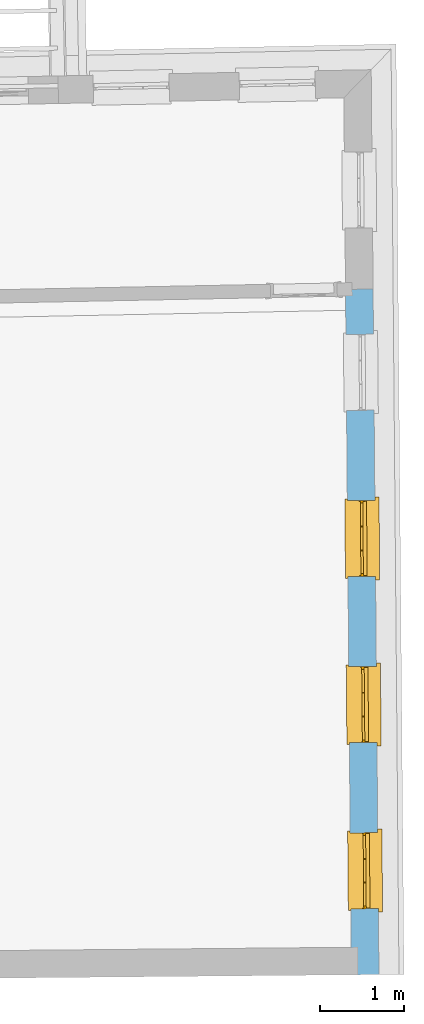
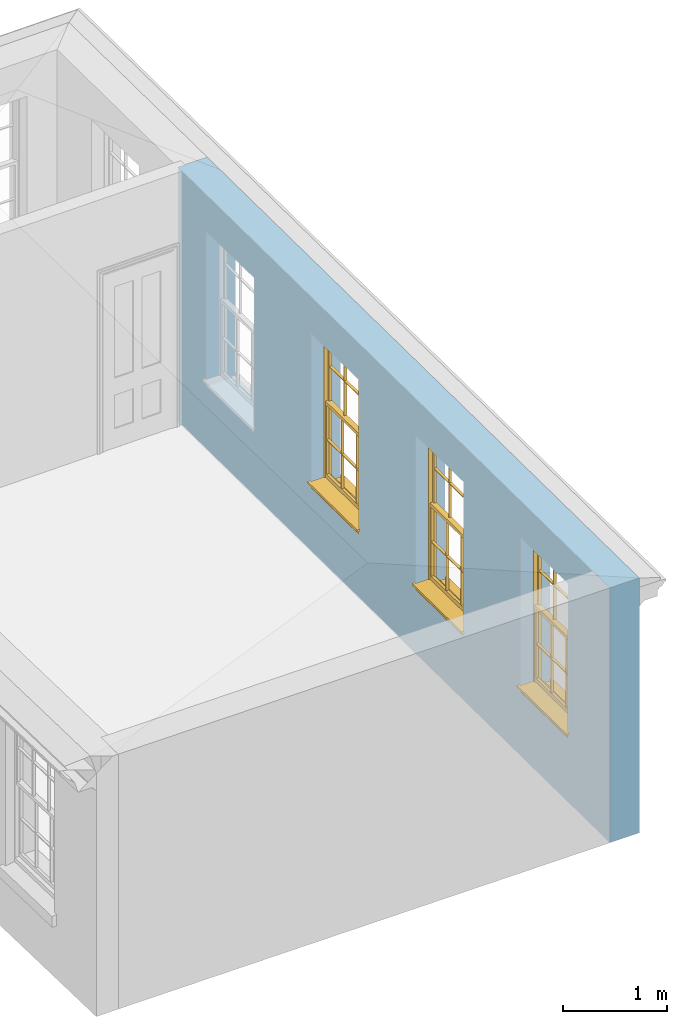
# One storey, part 4 of 11: 3 windows, 4 openings, plus 1 element that does not belong to this part.
"""IFC2X3 building model written with IfcOpenShell, lengths in metres."""

from ifc_helpers import new_model, si_unit, frame, origin, place, context, subcontext, project, spatial, polyline, outline, extrude, faceted_brep, material, layer, layer_set, layer_usage, element, fill, save


model = new_model("IFC2X3")

# Units and contexts
model_context = context("Model", 3, world=origin())
body_context = subcontext(model_context, "Body", "Model", "MODEL_VIEW")
ifc_project = project(units=[si_unit("PLANEANGLEUNIT", "RADIAN"), si_unit("MASSUNIT", "GRAM", prefix="KILO"), si_unit("FORCEUNIT", "NEWTON", prefix="KILO"), si_unit("LENGTHUNIT", "METRE")], contexts=[model_context])

# Site, building, storey
site_placement = place(None, origin())
site = spatial("IfcSite", under=ifc_project, at=site_placement, CompositionType="ELEMENT")
building_placement = place(None, origin())
building = spatial("IfcBuilding", under=site, at=building_placement, Name="Building plot-11", CompositionType="ELEMENT")
storey_placement = place(None, frame((0.0, 0.0, 5.3)))
storey = spatial("IfcBuildingStorey", under=building, at=storey_placement, Name="Floor 1", CompositionType="ELEMENT", Elevation=5.3)

# Wall, openings, windows
ifc_material = material(Name="Masonry")
ifc_layer = layer(ifc_material, 0.33, ventilated=False)
ifc_layer_set = layer_set([ifc_layer], Name="My Wall")
ifc_layer_usage = layer_usage(ifc_layer_set, "AXIS2", "NEGATIVE", 0.08)
wall_placement = place(storey_placement, origin())
wall = element("IfcWallStandardCase", 1, at=wall_placement, inside=storey, material=ifc_layer_usage, Name="exterior", context=body_context, shape_type="SweptSolid", body=[
    extrude(outline(polyline([(65.5837615155297, 12.2179906948306), (65.913749407515, 12.220817555827), (65.8434428524129, 20.4279108442136), (65.5134549604276, 20.4250839832172), (65.5837615155297, 12.2179906948306)])), origin(), (0.0, 0.0, 1.0), 3.0),
])
opening_1_placement = place(storey_placement, frame((0.0, 0.0, 0.75)))
opening_1 = element("IfcOpeningElement", 2, at=opening_1_placement, cuts=wall, Name="Opening", ObjectType="Opening", context=body_context, shape_type="SweptSolid", body=[
    extrude(outline(polyline([(65.9069848636133, 13.0104628851131), (65.8991895802596, 13.9204294963454), (65.5692016882743, 13.9176026353489), (65.576996971628, 13.0076360241167), (65.9069848636133, 13.0104628851131)])), origin(), (0.0, 0.0, 1.0), 1.82),
])
opening_2_placement = place(storey_placement, frame((0.0, 0.0, 0.75)))
opening_2 = element("IfcOpeningElement", 3, at=opening_2_placement, cuts=wall, Name="Opening", ObjectType="Opening", context=body_context, shape_type="SweptSolid", body=[
    extrude(outline(polyline([(65.889943615178, 14.9997385003944), (65.8821483318243, 15.9097051116266), (65.552160439839, 15.9068782506302), (65.5599557231927, 14.996911639398), (65.889943615178, 14.9997385003944)])), origin(), (0.0, 0.0, 1.0), 1.82),
])
opening_3_placement = place(storey_placement, frame((0.0, 0.0, 0.75)))
opening_3 = element("IfcOpeningElement", 4, at=opening_3_placement, cuts=wall, Name="Opening", ObjectType="Opening", context=body_context, shape_type="SweptSolid", body=[
    extrude(outline(polyline([(65.8729023667427, 16.9890141156756), (65.865107083389, 17.8989807269079), (65.5351191914037, 17.8961538659114), (65.5429144747574, 16.9861872546792), (65.8729023667427, 16.9890141156756)])), origin(), (0.0, 0.0, 1.0), 1.82),
])
opening_4_placement = place(storey_placement, frame((0.0, 0.0, 0.75)))
element("IfcOpeningElement", 5, at=opening_4_placement, cuts=wall, Name="Opening", ObjectType="Opening", context=body_context, shape_type="SweptSolid", body=[
    extrude(outline(polyline([(65.8558611183074, 18.9782897309569), (65.8480658349537, 19.8882563421891), (65.5180779429683, 19.8854294811927), (65.5258732263221, 18.9754628699605), (65.8558611183074, 18.9782897309569)])), origin(), (0.0, 0.0, 1.0), 1.82),
])
window_1_placement = place(storey_placement, frame((65.6569940363517, 13.0083213237522, 0.75), z_axis=(0.0, 0.0, 1.0), x_axis=(-0.00779528335375801, 0.909966611232212, 0.0)))
window_1 = element("IfcWindow", 6, at=window_1_placement, inside=storey, Name="bedroom outside window", OverallHeight=1.82, OverallWidth=0.91, context=body_context, shape_type="Brep", held_by="IfcProductRepresentation", body=[
    faceted_brep([(0.033125, -0.105, 0.975209), (0.01, -0.105, 0.975209), (0.033125, -0.105, 1.376042), (0.876875, -0.105, 0.975209), (0.876875, -0.105, 1.376042), (0.9, -0.105, 0.975209), (0.876875, -0.105, 1.386042), (0.876875, -0.105, 1.786875), (0.9, -0.105, 1.81), (0.033125, -0.105, 1.786875), (0.033125, -0.105, 1.386042), (0.01, -0.105, 1.81), (0.876875, -0.135, 1.376042), (0.876875, -0.135, 0.975209), (0.9, -0.135, 0.937083), (0.033125, -0.135, 1.786875), (0.01, -0.135, 1.81), (0.033125, -0.135, 1.386042), (0.01, -0.135, 0.937083), (0.033125, -0.135, 0.975209), (0.033125, -0.135, 1.376042), (0.876875, -0.135, 1.786875), (0.876875, -0.135, 1.386042), (0.9, -0.135, 1.81), (0.033125, -0.105, 0.937083), (0.01, -0.105, 0.937083), (0.033125, -0.105, 0.53625), (0.876875, -0.105, 0.937083), (0.876875, -0.105, 0.53625), (0.9, -0.105, 0.937083), (0.876875, -0.105, 0.52625), (0.876875, -0.105, 0.125417), (0.9, -0.105, 0.077167), (0.033125, -0.105, 0.125417), (0.033125, -0.105, 0.52625), (0.01, -0.105, 0.077167), (-0.0425, -0.25, 0.01), (-0.0425, -0.3, 0.001667), (0.0, -0.25, 0.01), (0.9525, -0.25, 0.01), (0.91, -0.25, 0.01), (0.9525, -0.3, 0.001667), (-0.02, 0.08, 0.077167), (0.0, 0.08, 0.077167), (-0.02, 0.11, 0.077167), (0.0, -0.06, 0.077167), (0.01, -0.06, 0.077167), (0.91, -0.06, 0.077167), (0.91, 0.08, 0.077167), (0.9, -0.06, 0.077167), (0.93, 0.08, 0.077167), (0.93, 0.11, 0.077167), (0.01, -0.075, 0.975209), (0.9, -0.075, 0.975209), (0.876875, -0.075, 0.125417), (0.876875, -0.075, 0.52625), (0.9, -0.075, 0.077167), (0.876875, -0.075, 0.53625), (0.876875, -0.075, 0.937083), (0.033125, -0.075, 0.125417), (0.01, -0.075, 0.077167), (0.033125, -0.075, 0.52625), (0.033125, -0.075, 0.937083), (0.033125, -0.075, 0.53625), (-0.02, 0.08, 0.052167), (-0.02, 0.11, 0.052167), (0.93, 0.11, 0.052167), (0.93, 0.08, 0.052167), (0.91, 0.08, 0.052167), (0.0, 0.08, 0.052167), (0.91, -0.15, 0.026667), (0.0, -0.15, 0.026667), (-0.0425, -0.3, -0.123333), (0.9525, -0.3, -0.123333), (-0.0425, -0.25, -0.123333), (0.9525, -0.25, -0.123333), (0.01, -0.06, 1.81), (0.9, -0.06, 1.81), (0.0, -0.06, 1.82), (0.91, -0.06, 1.82), (0.01, -0.15, 0.077167), (0.9, -0.15, 0.077167), (0.592292, -0.105, 0.125417), (0.592292, -0.075, 0.125417), (0.317708, -0.075, 0.125417), (0.317708, -0.105, 0.125417), (0.592292, -0.105, 0.53625), (0.317708, -0.105, 0.53625), (0.317708, -0.105, 0.52625), (0.592292, -0.105, 0.52625), (0.592292, -0.075, 0.53625), (0.317708, -0.075, 0.53625), (0.592292, -0.135, 1.386042), (0.592292, -0.105, 1.386042), (0.317708, -0.105, 1.386042), (0.317708, -0.135, 1.386042), (0.317708, -0.135, 1.376042), (0.592292, -0.135, 1.376042), (0.317708, -0.105, 1.376042), (0.592292, -0.105, 1.376042), (0.602292, -0.135, 1.376042), (0.592292, -0.135, 0.975209), (0.602292, -0.135, 0.975209), (0.602292, -0.105, 0.975209), (0.592292, -0.105, 0.975209), (0.602292, -0.105, 1.376042), (0.602292, -0.075, 0.53625), (0.602292, -0.105, 0.53625), (0.317708, -0.075, 0.52625), (0.307708, -0.075, 0.125417), (0.307708, -0.075, 0.52625), (0.602292, -0.075, 0.52625), (0.602292, -0.075, 0.125417), (0.592292, -0.075, 0.52625), (0.307708, -0.075, 0.53625), (0.317708, -0.075, 0.937083), (0.307708, -0.075, 0.937083), (0.602292, -0.075, 0.937083), (0.592292, -0.075, 0.937083), (0.307708, -0.105, 0.52625), (0.307708, -0.105, 0.125417), (0.307708, -0.105, 0.53625), (0.307708, -0.105, 0.937083), (0.592292, -0.105, 0.937083), (0.317708, -0.105, 0.937083), (0.602292, -0.105, 0.937083), (0.602292, -0.105, 0.52625), (0.602292, -0.105, 0.125417), (0.307708, -0.135, 1.386042), (0.307708, -0.135, 1.376042), (0.307708, -0.135, 0.975209), (0.317708, -0.135, 0.975209), (0.317708, -0.135, 1.786875), (0.307708, -0.135, 1.786875), (0.602292, -0.135, 1.786875), (0.592292, -0.135, 1.786875), (0.602292, -0.135, 1.386042), (0.602292, -0.105, 1.386042), (0.307708, -0.105, 1.386042), (0.307708, -0.105, 1.786875), (0.317708, -0.105, 1.786875), (0.592292, -0.105, 1.786875), (0.602292, -0.105, 1.786875), (0.307708, -0.105, 1.376042), (0.317708, -0.105, 0.975209), (0.307708, -0.105, 0.975209), (0.91, -0.15, 1.82), (0.9, -0.15, 1.81), (0.01, -0.15, 1.81), (0.0, -0.15, 1.82), (0.91, -0.25, 0.0), (0.0, -0.25, 0.0), (0.91, 0.08, 0.0), (0.0, 0.08, 0.0)], [[[0, 1, 2]], [[3, 4, 5]], [[6, 7, 8]], [[9, 10, 11]], [[12, 13, 14]], [[15, 16, 17]], [[18, 19, 20]], [[21, 22, 23]], [[24, 25, 26]], [[27, 28, 29]], [[30, 31, 32]], [[33, 34, 35]], [[14, 27, 29]], [[25, 24, 18]], [[36, 37, 38]], [[39, 40, 41]], [[42, 43, 44]], [[45, 46, 43]], [[47, 48, 49]], [[50, 51, 48]], [[1, 0, 52]], [[5, 53, 3]], [[54, 55, 56]], [[57, 58, 53]], [[59, 60, 61]], [[62, 63, 52]], [[48, 43, 46, 49]], [[51, 44, 43, 48]], [[64, 42, 44, 65]], [[65, 44, 51, 66]], [[66, 51, 50, 67]], [[65, 66, 68, 69]], [[60, 56, 49, 46]], [[70, 71, 38, 40]], [[37, 41, 40, 38]], [[37, 72, 73, 41]], [[74, 75, 73, 72]], [[8, 11, 76, 77]], [[76, 78, 79, 77]], [[32, 35, 80, 81]], [[81, 80, 71, 70]], [[82, 83, 84, 85]], [[86, 87, 88, 89]], [[86, 90, 91, 87]], [[92, 93, 94, 95]], [[92, 95, 96, 97]], [[96, 98, 99, 97]], [[100, 97, 101, 102]], [[103, 104, 99, 105]], [[97, 99, 104, 101]], [[102, 103, 105, 100]], [[28, 57, 106, 107]], [[108, 84, 109, 110]], [[111, 112, 83, 113]], [[114, 110, 61, 63]], [[90, 113, 108, 91]], [[115, 91, 114, 116]], [[117, 106, 90, 118]], [[111, 106, 57, 55]], [[119, 110, 109, 120]], [[34, 61, 110, 119]], [[89, 113, 83, 82]], [[88, 108, 113, 89]], [[85, 84, 108, 88]], [[121, 114, 63, 26]], [[122, 116, 114, 121]], [[123, 118, 90, 86]], [[87, 91, 115, 124]], [[107, 106, 117, 125]], [[126, 111, 55, 30]], [[127, 112, 111, 126]], [[126, 30, 28, 107]], [[88, 119, 120, 85]], [[126, 89, 82, 127]], [[125, 123, 86, 107]], [[121, 26, 34, 119]], [[124, 122, 121, 87]], [[128, 17, 20, 129]], [[96, 129, 130, 131]], [[132, 133, 128, 95]], [[134, 135, 92, 136]], [[100, 12, 22, 136]], [[137, 6, 4, 105]], [[94, 138, 139, 140]], [[137, 93, 141, 142]], [[99, 98, 94, 93]], [[143, 2, 10, 138]], [[144, 145, 143, 98]], [[129, 143, 145, 130]], [[20, 2, 143, 129]], [[131, 144, 98, 96]], [[128, 138, 10, 17]], [[133, 139, 138, 128]], [[135, 141, 93, 92]], [[95, 94, 140, 132]], [[22, 6, 137, 136]], [[136, 137, 142, 134]], [[100, 105, 4, 12]], [[107, 86, 89, 126]], [[106, 111, 113, 90]], [[91, 108, 110, 114]], [[87, 121, 119, 88]], [[97, 100, 136, 92]], [[129, 96, 95, 128]], [[98, 143, 138, 94]], [[105, 99, 93, 137]], [[131, 101, 104, 144]], [[124, 115, 118, 123]], [[132, 140, 141, 135]], [[120, 109, 59, 33]], [[15, 9, 139, 133]], [[134, 142, 7, 21]], [[31, 54, 112, 127]], [[36, 74, 72, 37]], [[39, 41, 73, 75]], [[18, 14, 101, 131]], [[23, 16, 132, 135]], [[83, 56, 60, 84]], [[52, 53, 118, 115]], [[53, 52, 144, 104]], [[11, 8, 141, 140]], [[14, 18, 124, 123]], [[2, 1, 11, 10]], [[8, 5, 4, 6]], [[57, 53, 56, 55]], [[60, 52, 63, 61]], [[26, 25, 35, 34]], [[32, 29, 28, 30]], [[14, 23, 22, 12]], [[18, 20, 17, 16]], [[19, 0, 2, 20]], [[17, 10, 9, 15]], [[12, 4, 3, 13]], [[21, 7, 6, 22]], [[27, 58, 57, 28]], [[30, 55, 54, 31]], [[33, 59, 61, 34]], [[26, 63, 62, 24]], [[5, 8, 77, 53]], [[76, 11, 1, 52]], [[46, 45, 78, 76]], [[49, 77, 79, 47]], [[70, 146, 147, 81]], [[71, 80, 148, 149]], [[19, 130, 145, 0]], [[102, 13, 3, 103]], [[116, 122, 24, 62]], [[29, 32, 81, 14]], [[80, 35, 25, 18]], [[60, 46, 76, 52]], [[77, 49, 56, 53]], [[23, 14, 81, 147]], [[16, 148, 80, 18]], [[35, 85, 120]], [[120, 33, 35]], [[127, 82, 32]], [[32, 31, 127]], [[32, 82, 85, 35]], [[102, 101, 14]], [[14, 13, 102]], [[18, 131, 130]], [[130, 19, 18]], [[134, 21, 23]], [[23, 135, 134]], [[16, 15, 133]], [[133, 132, 16]], [[11, 140, 139]], [[139, 9, 11]], [[142, 141, 8]], [[8, 7, 142]], [[23, 147, 148, 16]], [[146, 149, 148, 147]], [[52, 115, 116]], [[116, 62, 52]], [[118, 53, 117]], [[58, 117, 53]], [[27, 125, 117, 58]], [[56, 83, 112]], [[112, 54, 56]], [[109, 84, 60]], [[60, 59, 109]], [[125, 27, 14]], [[14, 123, 125]], [[122, 124, 18]], [[18, 24, 122]], [[145, 144, 52]], [[52, 0, 145]], [[103, 3, 53]], [[53, 104, 103]], [[79, 78, 149, 146]], [[78, 45, 71, 149]], [[146, 70, 47, 79]], [[150, 75, 74, 151]], [[68, 66, 67]], [[48, 68, 67, 50]], [[69, 64, 65]], [[42, 64, 69, 43]], [[69, 68, 152, 153]], [[70, 68, 48, 47]], [[150, 152, 68, 70]], [[43, 69, 71, 45]], [[69, 153, 151, 71]], [[152, 150, 151, 153]], [[38, 151, 74, 36]], [[71, 151, 38]], [[39, 75, 150, 40]], [[40, 150, 70]]]),
])
fill(opening_1, window_1)
window_2_placement = place(storey_placement, frame((65.6399527879164, 14.9975969390335, 0.75), z_axis=(0.0, 0.0, 1.0), x_axis=(-0.00779528335375801, 0.909966611232212, 0.0)))
window_2 = element("IfcWindow", 7, at=window_2_placement, inside=storey, Name="bedroom outside window", OverallHeight=1.82, OverallWidth=0.91, context=body_context, shape_type="Brep", held_by="IfcProductRepresentation", body=[
    faceted_brep([(0.033125, -0.105, 0.975209), (0.01, -0.105, 0.975209), (0.033125, -0.105, 1.376042), (0.876875, -0.105, 0.975209), (0.876875, -0.105, 1.376042), (0.9, -0.105, 0.975209), (0.876875, -0.105, 1.386042), (0.876875, -0.105, 1.786875), (0.9, -0.105, 1.81), (0.033125, -0.105, 1.786875), (0.033125, -0.105, 1.386042), (0.01, -0.105, 1.81), (0.876875, -0.135, 1.376042), (0.876875, -0.135, 0.975209), (0.9, -0.135, 0.937083), (0.033125, -0.135, 1.786875), (0.01, -0.135, 1.81), (0.033125, -0.135, 1.386042), (0.01, -0.135, 0.937083), (0.033125, -0.135, 0.975209), (0.033125, -0.135, 1.376042), (0.876875, -0.135, 1.786875), (0.876875, -0.135, 1.386042), (0.9, -0.135, 1.81), (0.033125, -0.105, 0.937083), (0.01, -0.105, 0.937083), (0.033125, -0.105, 0.53625), (0.876875, -0.105, 0.937083), (0.876875, -0.105, 0.53625), (0.9, -0.105, 0.937083), (0.876875, -0.105, 0.52625), (0.876875, -0.105, 0.125417), (0.9, -0.105, 0.077167), (0.033125, -0.105, 0.125417), (0.033125, -0.105, 0.52625), (0.01, -0.105, 0.077167), (-0.0425, -0.25, 0.01), (-0.0425, -0.3, 0.001667), (0.0, -0.25, 0.01), (0.9525, -0.25, 0.01), (0.91, -0.25, 0.01), (0.9525, -0.3, 0.001667), (-0.02, 0.08, 0.077167), (0.0, 0.08, 0.077167), (-0.02, 0.11, 0.077167), (0.0, -0.06, 0.077167), (0.01, -0.06, 0.077167), (0.91, -0.06, 0.077167), (0.91, 0.08, 0.077167), (0.9, -0.06, 0.077167), (0.93, 0.08, 0.077167), (0.93, 0.11, 0.077167), (0.01, -0.075, 0.975209), (0.9, -0.075, 0.975209), (0.876875, -0.075, 0.125417), (0.876875, -0.075, 0.52625), (0.9, -0.075, 0.077167), (0.876875, -0.075, 0.53625), (0.876875, -0.075, 0.937083), (0.033125, -0.075, 0.125417), (0.01, -0.075, 0.077167), (0.033125, -0.075, 0.52625), (0.033125, -0.075, 0.937083), (0.033125, -0.075, 0.53625), (-0.02, 0.08, 0.052167), (-0.02, 0.11, 0.052167), (0.93, 0.11, 0.052167), (0.93, 0.08, 0.052167), (0.91, 0.08, 0.052167), (0.0, 0.08, 0.052167), (0.91, -0.15, 0.026667), (0.0, -0.15, 0.026667), (-0.0425, -0.3, -0.123333), (0.9525, -0.3, -0.123333), (-0.0425, -0.25, -0.123333), (0.9525, -0.25, -0.123333), (0.01, -0.06, 1.81), (0.9, -0.06, 1.81), (0.0, -0.06, 1.82), (0.91, -0.06, 1.82), (0.01, -0.15, 0.077167), (0.9, -0.15, 0.077167), (0.592292, -0.105, 0.125417), (0.592292, -0.075, 0.125417), (0.317708, -0.075, 0.125417), (0.317708, -0.105, 0.125417), (0.592292, -0.105, 0.53625), (0.317708, -0.105, 0.53625), (0.317708, -0.105, 0.52625), (0.592292, -0.105, 0.52625), (0.592292, -0.075, 0.53625), (0.317708, -0.075, 0.53625), (0.592292, -0.135, 1.386042), (0.592292, -0.105, 1.386042), (0.317708, -0.105, 1.386042), (0.317708, -0.135, 1.386042), (0.317708, -0.135, 1.376042), (0.592292, -0.135, 1.376042), (0.317708, -0.105, 1.376042), (0.592292, -0.105, 1.376042), (0.602292, -0.135, 1.376042), (0.592292, -0.135, 0.975209), (0.602292, -0.135, 0.975209), (0.602292, -0.105, 0.975209), (0.592292, -0.105, 0.975209), (0.602292, -0.105, 1.376042), (0.602292, -0.075, 0.53625), (0.602292, -0.105, 0.53625), (0.317708, -0.075, 0.52625), (0.307708, -0.075, 0.125417), (0.307708, -0.075, 0.52625), (0.602292, -0.075, 0.52625), (0.602292, -0.075, 0.125417), (0.592292, -0.075, 0.52625), (0.307708, -0.075, 0.53625), (0.317708, -0.075, 0.937083), (0.307708, -0.075, 0.937083), (0.602292, -0.075, 0.937083), (0.592292, -0.075, 0.937083), (0.307708, -0.105, 0.52625), (0.307708, -0.105, 0.125417), (0.307708, -0.105, 0.53625), (0.307708, -0.105, 0.937083), (0.592292, -0.105, 0.937083), (0.317708, -0.105, 0.937083), (0.602292, -0.105, 0.937083), (0.602292, -0.105, 0.52625), (0.602292, -0.105, 0.125417), (0.307708, -0.135, 1.386042), (0.307708, -0.135, 1.376042), (0.307708, -0.135, 0.975209), (0.317708, -0.135, 0.975209), (0.317708, -0.135, 1.786875), (0.307708, -0.135, 1.786875), (0.602292, -0.135, 1.786875), (0.592292, -0.135, 1.786875), (0.602292, -0.135, 1.386042), (0.602292, -0.105, 1.386042), (0.307708, -0.105, 1.386042), (0.307708, -0.105, 1.786875), (0.317708, -0.105, 1.786875), (0.592292, -0.105, 1.786875), (0.602292, -0.105, 1.786875), (0.307708, -0.105, 1.376042), (0.317708, -0.105, 0.975209), (0.307708, -0.105, 0.975209), (0.91, -0.15, 1.82), (0.9, -0.15, 1.81), (0.01, -0.15, 1.81), (0.0, -0.15, 1.82), (0.91, -0.25, 0.0), (0.0, -0.25, 0.0), (0.91, 0.08, 0.0), (0.0, 0.08, 0.0)], [[[0, 1, 2]], [[3, 4, 5]], [[6, 7, 8]], [[9, 10, 11]], [[12, 13, 14]], [[15, 16, 17]], [[18, 19, 20]], [[21, 22, 23]], [[24, 25, 26]], [[27, 28, 29]], [[30, 31, 32]], [[33, 34, 35]], [[14, 27, 29]], [[25, 24, 18]], [[36, 37, 38]], [[39, 40, 41]], [[42, 43, 44]], [[45, 46, 43]], [[47, 48, 49]], [[50, 51, 48]], [[1, 0, 52]], [[5, 53, 3]], [[54, 55, 56]], [[57, 58, 53]], [[59, 60, 61]], [[62, 63, 52]], [[48, 43, 46, 49]], [[51, 44, 43, 48]], [[64, 42, 44, 65]], [[65, 44, 51, 66]], [[66, 51, 50, 67]], [[65, 66, 68, 69]], [[60, 56, 49, 46]], [[70, 71, 38, 40]], [[37, 41, 40, 38]], [[37, 72, 73, 41]], [[74, 75, 73, 72]], [[8, 11, 76, 77]], [[76, 78, 79, 77]], [[32, 35, 80, 81]], [[81, 80, 71, 70]], [[82, 83, 84, 85]], [[86, 87, 88, 89]], [[86, 90, 91, 87]], [[92, 93, 94, 95]], [[92, 95, 96, 97]], [[96, 98, 99, 97]], [[100, 97, 101, 102]], [[103, 104, 99, 105]], [[97, 99, 104, 101]], [[102, 103, 105, 100]], [[28, 57, 106, 107]], [[108, 84, 109, 110]], [[111, 112, 83, 113]], [[114, 110, 61, 63]], [[90, 113, 108, 91]], [[115, 91, 114, 116]], [[117, 106, 90, 118]], [[111, 106, 57, 55]], [[119, 110, 109, 120]], [[34, 61, 110, 119]], [[89, 113, 83, 82]], [[88, 108, 113, 89]], [[85, 84, 108, 88]], [[121, 114, 63, 26]], [[122, 116, 114, 121]], [[123, 118, 90, 86]], [[87, 91, 115, 124]], [[107, 106, 117, 125]], [[126, 111, 55, 30]], [[127, 112, 111, 126]], [[126, 30, 28, 107]], [[88, 119, 120, 85]], [[126, 89, 82, 127]], [[125, 123, 86, 107]], [[121, 26, 34, 119]], [[124, 122, 121, 87]], [[128, 17, 20, 129]], [[96, 129, 130, 131]], [[132, 133, 128, 95]], [[134, 135, 92, 136]], [[100, 12, 22, 136]], [[137, 6, 4, 105]], [[94, 138, 139, 140]], [[137, 93, 141, 142]], [[99, 98, 94, 93]], [[143, 2, 10, 138]], [[144, 145, 143, 98]], [[129, 143, 145, 130]], [[20, 2, 143, 129]], [[131, 144, 98, 96]], [[128, 138, 10, 17]], [[133, 139, 138, 128]], [[135, 141, 93, 92]], [[95, 94, 140, 132]], [[22, 6, 137, 136]], [[136, 137, 142, 134]], [[100, 105, 4, 12]], [[107, 86, 89, 126]], [[106, 111, 113, 90]], [[91, 108, 110, 114]], [[87, 121, 119, 88]], [[97, 100, 136, 92]], [[129, 96, 95, 128]], [[98, 143, 138, 94]], [[105, 99, 93, 137]], [[131, 101, 104, 144]], [[124, 115, 118, 123]], [[132, 140, 141, 135]], [[120, 109, 59, 33]], [[15, 9, 139, 133]], [[134, 142, 7, 21]], [[31, 54, 112, 127]], [[36, 74, 72, 37]], [[39, 41, 73, 75]], [[18, 14, 101, 131]], [[23, 16, 132, 135]], [[83, 56, 60, 84]], [[52, 53, 118, 115]], [[53, 52, 144, 104]], [[11, 8, 141, 140]], [[14, 18, 124, 123]], [[2, 1, 11, 10]], [[8, 5, 4, 6]], [[57, 53, 56, 55]], [[60, 52, 63, 61]], [[26, 25, 35, 34]], [[32, 29, 28, 30]], [[14, 23, 22, 12]], [[18, 20, 17, 16]], [[19, 0, 2, 20]], [[17, 10, 9, 15]], [[12, 4, 3, 13]], [[21, 7, 6, 22]], [[27, 58, 57, 28]], [[30, 55, 54, 31]], [[33, 59, 61, 34]], [[26, 63, 62, 24]], [[5, 8, 77, 53]], [[76, 11, 1, 52]], [[46, 45, 78, 76]], [[49, 77, 79, 47]], [[70, 146, 147, 81]], [[71, 80, 148, 149]], [[19, 130, 145, 0]], [[102, 13, 3, 103]], [[116, 122, 24, 62]], [[29, 32, 81, 14]], [[80, 35, 25, 18]], [[60, 46, 76, 52]], [[77, 49, 56, 53]], [[23, 14, 81, 147]], [[16, 148, 80, 18]], [[35, 85, 120]], [[120, 33, 35]], [[127, 82, 32]], [[32, 31, 127]], [[32, 82, 85, 35]], [[102, 101, 14]], [[14, 13, 102]], [[18, 131, 130]], [[130, 19, 18]], [[134, 21, 23]], [[23, 135, 134]], [[16, 15, 133]], [[133, 132, 16]], [[11, 140, 139]], [[139, 9, 11]], [[142, 141, 8]], [[8, 7, 142]], [[23, 147, 148, 16]], [[146, 149, 148, 147]], [[52, 115, 116]], [[116, 62, 52]], [[118, 53, 117]], [[58, 117, 53]], [[27, 125, 117, 58]], [[56, 83, 112]], [[112, 54, 56]], [[109, 84, 60]], [[60, 59, 109]], [[125, 27, 14]], [[14, 123, 125]], [[122, 124, 18]], [[18, 24, 122]], [[145, 144, 52]], [[52, 0, 145]], [[103, 3, 53]], [[53, 104, 103]], [[79, 78, 149, 146]], [[78, 45, 71, 149]], [[146, 70, 47, 79]], [[150, 75, 74, 151]], [[68, 66, 67]], [[48, 68, 67, 50]], [[69, 64, 65]], [[42, 64, 69, 43]], [[69, 68, 152, 153]], [[70, 68, 48, 47]], [[150, 152, 68, 70]], [[43, 69, 71, 45]], [[69, 153, 151, 71]], [[152, 150, 151, 153]], [[38, 151, 74, 36]], [[71, 151, 38]], [[39, 75, 150, 40]], [[40, 150, 70]]]),
])
fill(opening_2, window_2)
window_3_placement = place(storey_placement, frame((65.6229115394811, 16.9868725543147, 0.75), z_axis=(0.0, 0.0, 1.0), x_axis=(-0.00779528335375801, 0.90996661123221, 0.0)))
window_3 = element("IfcWindow", 8, at=window_3_placement, inside=storey, Name="bedroom outside window", OverallHeight=1.82, OverallWidth=0.91, context=body_context, shape_type="Brep", held_by="IfcProductRepresentation", body=[
    faceted_brep([(0.033125, -0.105, 0.975209), (0.01, -0.105, 0.975209), (0.033125, -0.105, 1.376042), (0.876875, -0.105, 0.975209), (0.876875, -0.105, 1.376042), (0.9, -0.105, 0.975209), (0.876875, -0.105, 1.386042), (0.876875, -0.105, 1.786875), (0.9, -0.105, 1.81), (0.033125, -0.105, 1.786875), (0.033125, -0.105, 1.386042), (0.01, -0.105, 1.81), (0.876875, -0.135, 1.376042), (0.876875, -0.135, 0.975209), (0.9, -0.135, 0.937083), (0.033125, -0.135, 1.786875), (0.01, -0.135, 1.81), (0.033125, -0.135, 1.386042), (0.01, -0.135, 0.937083), (0.033125, -0.135, 0.975209), (0.033125, -0.135, 1.376042), (0.876875, -0.135, 1.786875), (0.876875, -0.135, 1.386042), (0.9, -0.135, 1.81), (0.033125, -0.105, 0.937083), (0.01, -0.105, 0.937083), (0.033125, -0.105, 0.53625), (0.876875, -0.105, 0.937083), (0.876875, -0.105, 0.53625), (0.9, -0.105, 0.937083), (0.876875, -0.105, 0.52625), (0.876875, -0.105, 0.125417), (0.9, -0.105, 0.077167), (0.033125, -0.105, 0.125417), (0.033125, -0.105, 0.52625), (0.01, -0.105, 0.077167), (-0.0425, -0.25, 0.01), (-0.0425, -0.3, 0.001667), (0.0, -0.25, 0.01), (0.9525, -0.25, 0.01), (0.91, -0.25, 0.01), (0.9525, -0.3, 0.001667), (-0.02, 0.08, 0.077167), (0.0, 0.08, 0.077167), (-0.02, 0.11, 0.077167), (0.0, -0.06, 0.077167), (0.01, -0.06, 0.077167), (0.91, -0.06, 0.077167), (0.91, 0.08, 0.077167), (0.9, -0.06, 0.077167), (0.93, 0.08, 0.077167), (0.93, 0.11, 0.077167), (0.01, -0.075, 0.975209), (0.9, -0.075, 0.975209), (0.876875, -0.075, 0.125417), (0.876875, -0.075, 0.52625), (0.9, -0.075, 0.077167), (0.876875, -0.075, 0.53625), (0.876875, -0.075, 0.937083), (0.033125, -0.075, 0.125417), (0.01, -0.075, 0.077167), (0.033125, -0.075, 0.52625), (0.033125, -0.075, 0.937083), (0.033125, -0.075, 0.53625), (-0.02, 0.08, 0.052167), (-0.02, 0.11, 0.052167), (0.93, 0.11, 0.052167), (0.93, 0.08, 0.052167), (0.91, 0.08, 0.052167), (0.0, 0.08, 0.052167), (0.91, -0.15, 0.026667), (0.0, -0.15, 0.026667), (-0.0425, -0.3, -0.123333), (0.9525, -0.3, -0.123333), (-0.0425, -0.25, -0.123333), (0.9525, -0.25, -0.123333), (0.01, -0.06, 1.81), (0.9, -0.06, 1.81), (0.0, -0.06, 1.82), (0.91, -0.06, 1.82), (0.01, -0.15, 0.077167), (0.9, -0.15, 0.077167), (0.592292, -0.105, 0.125417), (0.592292, -0.075, 0.125417), (0.317708, -0.075, 0.125417), (0.317708, -0.105, 0.125417), (0.592292, -0.105, 0.53625), (0.317708, -0.105, 0.53625), (0.317708, -0.105, 0.52625), (0.592292, -0.105, 0.52625), (0.592292, -0.075, 0.53625), (0.317708, -0.075, 0.53625), (0.592292, -0.135, 1.386042), (0.592292, -0.105, 1.386042), (0.317708, -0.105, 1.386042), (0.317708, -0.135, 1.386042), (0.317708, -0.135, 1.376042), (0.592292, -0.135, 1.376042), (0.317708, -0.105, 1.376042), (0.592292, -0.105, 1.376042), (0.602292, -0.135, 1.376042), (0.592292, -0.135, 0.975209), (0.602292, -0.135, 0.975209), (0.602292, -0.105, 0.975209), (0.592292, -0.105, 0.975209), (0.602292, -0.105, 1.376042), (0.602292, -0.075, 0.53625), (0.602292, -0.105, 0.53625), (0.317708, -0.075, 0.52625), (0.307708, -0.075, 0.125417), (0.307708, -0.075, 0.52625), (0.602292, -0.075, 0.52625), (0.602292, -0.075, 0.125417), (0.592292, -0.075, 0.52625), (0.307708, -0.075, 0.53625), (0.317708, -0.075, 0.937083), (0.307708, -0.075, 0.937083), (0.602292, -0.075, 0.937083), (0.592292, -0.075, 0.937083), (0.307708, -0.105, 0.52625), (0.307708, -0.105, 0.125417), (0.307708, -0.105, 0.53625), (0.307708, -0.105, 0.937083), (0.592292, -0.105, 0.937083), (0.317708, -0.105, 0.937083), (0.602292, -0.105, 0.937083), (0.602292, -0.105, 0.52625), (0.602292, -0.105, 0.125417), (0.307708, -0.135, 1.386042), (0.307708, -0.135, 1.376042), (0.307708, -0.135, 0.975209), (0.317708, -0.135, 0.975209), (0.317708, -0.135, 1.786875), (0.307708, -0.135, 1.786875), (0.602292, -0.135, 1.786875), (0.592292, -0.135, 1.786875), (0.602292, -0.135, 1.386042), (0.602292, -0.105, 1.386042), (0.307708, -0.105, 1.386042), (0.307708, -0.105, 1.786875), (0.317708, -0.105, 1.786875), (0.592292, -0.105, 1.786875), (0.602292, -0.105, 1.786875), (0.307708, -0.105, 1.376042), (0.317708, -0.105, 0.975209), (0.307708, -0.105, 0.975209), (0.91, -0.15, 1.82), (0.9, -0.15, 1.81), (0.01, -0.15, 1.81), (0.0, -0.15, 1.82), (0.91, -0.25, 0.0), (0.0, -0.25, 0.0), (0.91, 0.08, 0.0), (0.0, 0.08, 0.0)], [[[0, 1, 2]], [[3, 4, 5]], [[6, 7, 8]], [[9, 10, 11]], [[12, 13, 14]], [[15, 16, 17]], [[18, 19, 20]], [[21, 22, 23]], [[24, 25, 26]], [[27, 28, 29]], [[30, 31, 32]], [[33, 34, 35]], [[14, 27, 29]], [[25, 24, 18]], [[36, 37, 38]], [[39, 40, 41]], [[42, 43, 44]], [[45, 46, 43]], [[47, 48, 49]], [[50, 51, 48]], [[1, 0, 52]], [[5, 53, 3]], [[54, 55, 56]], [[57, 58, 53]], [[59, 60, 61]], [[62, 63, 52]], [[48, 43, 46, 49]], [[51, 44, 43, 48]], [[64, 42, 44, 65]], [[65, 44, 51, 66]], [[66, 51, 50, 67]], [[65, 66, 68, 69]], [[60, 56, 49, 46]], [[70, 71, 38, 40]], [[37, 41, 40, 38]], [[37, 72, 73, 41]], [[74, 75, 73, 72]], [[8, 11, 76, 77]], [[76, 78, 79, 77]], [[32, 35, 80, 81]], [[81, 80, 71, 70]], [[82, 83, 84, 85]], [[86, 87, 88, 89]], [[86, 90, 91, 87]], [[92, 93, 94, 95]], [[92, 95, 96, 97]], [[96, 98, 99, 97]], [[100, 97, 101, 102]], [[103, 104, 99, 105]], [[97, 99, 104, 101]], [[102, 103, 105, 100]], [[28, 57, 106, 107]], [[108, 84, 109, 110]], [[111, 112, 83, 113]], [[114, 110, 61, 63]], [[90, 113, 108, 91]], [[115, 91, 114, 116]], [[117, 106, 90, 118]], [[111, 106, 57, 55]], [[119, 110, 109, 120]], [[34, 61, 110, 119]], [[89, 113, 83, 82]], [[88, 108, 113, 89]], [[85, 84, 108, 88]], [[121, 114, 63, 26]], [[122, 116, 114, 121]], [[123, 118, 90, 86]], [[87, 91, 115, 124]], [[107, 106, 117, 125]], [[126, 111, 55, 30]], [[127, 112, 111, 126]], [[126, 30, 28, 107]], [[88, 119, 120, 85]], [[126, 89, 82, 127]], [[125, 123, 86, 107]], [[121, 26, 34, 119]], [[124, 122, 121, 87]], [[128, 17, 20, 129]], [[96, 129, 130, 131]], [[132, 133, 128, 95]], [[134, 135, 92, 136]], [[100, 12, 22, 136]], [[137, 6, 4, 105]], [[94, 138, 139, 140]], [[137, 93, 141, 142]], [[99, 98, 94, 93]], [[143, 2, 10, 138]], [[144, 145, 143, 98]], [[129, 143, 145, 130]], [[20, 2, 143, 129]], [[131, 144, 98, 96]], [[128, 138, 10, 17]], [[133, 139, 138, 128]], [[135, 141, 93, 92]], [[95, 94, 140, 132]], [[22, 6, 137, 136]], [[136, 137, 142, 134]], [[100, 105, 4, 12]], [[107, 86, 89, 126]], [[106, 111, 113, 90]], [[91, 108, 110, 114]], [[87, 121, 119, 88]], [[97, 100, 136, 92]], [[129, 96, 95, 128]], [[98, 143, 138, 94]], [[105, 99, 93, 137]], [[131, 101, 104, 144]], [[124, 115, 118, 123]], [[132, 140, 141, 135]], [[120, 109, 59, 33]], [[15, 9, 139, 133]], [[134, 142, 7, 21]], [[31, 54, 112, 127]], [[36, 74, 72, 37]], [[39, 41, 73, 75]], [[18, 14, 101, 131]], [[23, 16, 132, 135]], [[83, 56, 60, 84]], [[52, 53, 118, 115]], [[53, 52, 144, 104]], [[11, 8, 141, 140]], [[14, 18, 124, 123]], [[2, 1, 11, 10]], [[8, 5, 4, 6]], [[57, 53, 56, 55]], [[60, 52, 63, 61]], [[26, 25, 35, 34]], [[32, 29, 28, 30]], [[14, 23, 22, 12]], [[18, 20, 17, 16]], [[19, 0, 2, 20]], [[17, 10, 9, 15]], [[12, 4, 3, 13]], [[21, 7, 6, 22]], [[27, 58, 57, 28]], [[30, 55, 54, 31]], [[33, 59, 61, 34]], [[26, 63, 62, 24]], [[5, 8, 77, 53]], [[76, 11, 1, 52]], [[46, 45, 78, 76]], [[49, 77, 79, 47]], [[70, 146, 147, 81]], [[71, 80, 148, 149]], [[19, 130, 145, 0]], [[102, 13, 3, 103]], [[116, 122, 24, 62]], [[29, 32, 81, 14]], [[80, 35, 25, 18]], [[60, 46, 76, 52]], [[77, 49, 56, 53]], [[23, 14, 81, 147]], [[16, 148, 80, 18]], [[35, 85, 120]], [[120, 33, 35]], [[127, 82, 32]], [[32, 31, 127]], [[32, 82, 85, 35]], [[102, 101, 14]], [[14, 13, 102]], [[18, 131, 130]], [[130, 19, 18]], [[134, 21, 23]], [[23, 135, 134]], [[16, 15, 133]], [[133, 132, 16]], [[11, 140, 139]], [[139, 9, 11]], [[142, 141, 8]], [[8, 7, 142]], [[23, 147, 148, 16]], [[146, 149, 148, 147]], [[52, 115, 116]], [[116, 62, 52]], [[118, 53, 117]], [[58, 117, 53]], [[27, 125, 117, 58]], [[56, 83, 112]], [[112, 54, 56]], [[109, 84, 60]], [[60, 59, 109]], [[125, 27, 14]], [[14, 123, 125]], [[122, 124, 18]], [[18, 24, 122]], [[145, 144, 52]], [[52, 0, 145]], [[103, 3, 53]], [[53, 104, 103]], [[79, 78, 149, 146]], [[78, 45, 71, 149]], [[146, 70, 47, 79]], [[150, 75, 74, 151]], [[68, 66, 67]], [[48, 68, 67, 50]], [[69, 64, 65]], [[42, 64, 69, 43]], [[69, 68, 152, 153]], [[70, 68, 48, 47]], [[150, 152, 68, 70]], [[43, 69, 71, 45]], [[69, 153, 151, 71]], [[152, 150, 151, 153]], [[38, 151, 74, 36]], [[71, 151, 38]], [[39, 75, 150, 40]], [[40, 150, 70]]]),
])
fill(opening_3, window_3)

save(model, "model.ifc")
